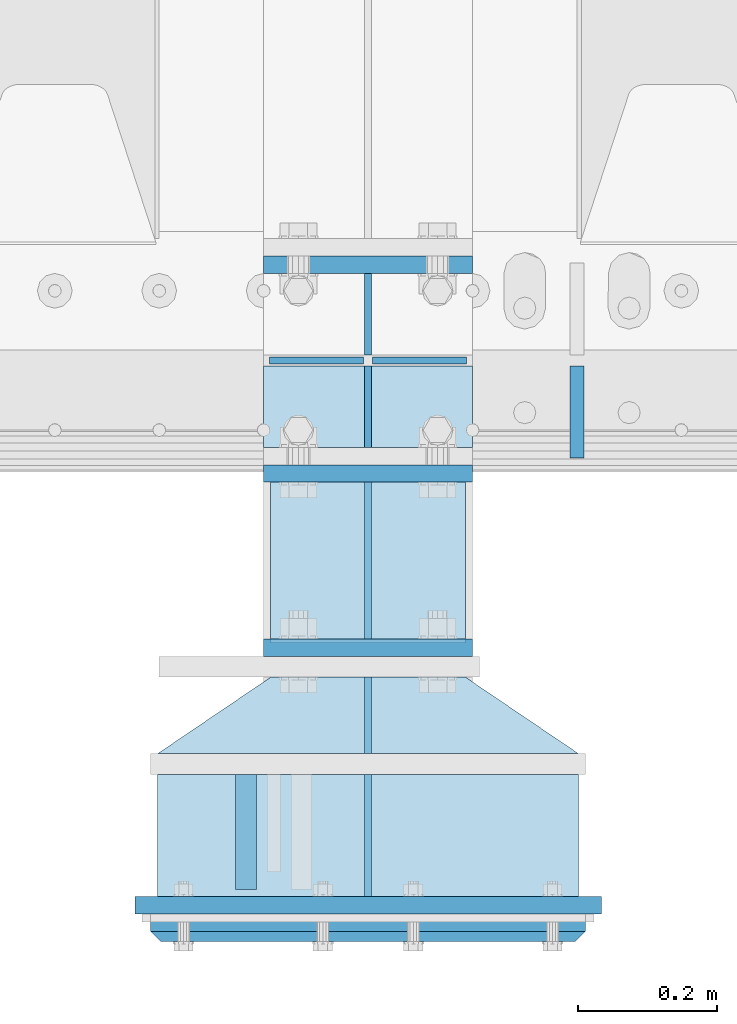
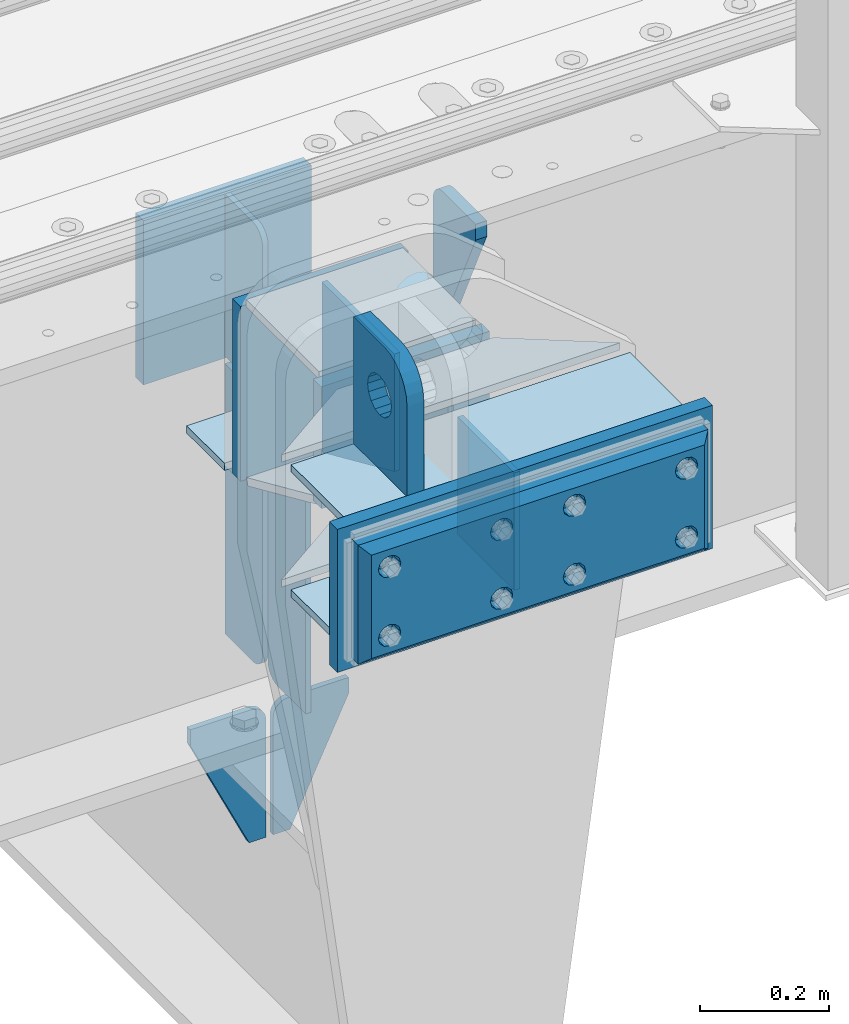
# One storey, part 178 of 208: 22 plates.
"""IFC2X3 building model written with IfcOpenShell, lengths in millimetres."""

import ifcopenshell
import ifcopenshell.guid

model = None  # the IFC model being written
_history = None  # IfcOwnerHistory: only IFC2X3 demands one
_inside = {}  # id of a spatial element -> (the spatial element, [elements in it])
_under = {}  # id of a project, library or spatial element -> (it, [spatial elements below it])
_declared = {}  # id of a project -> (the project, [libraries it declares])
_typed = {}  # id of a type object -> (the type object, [elements of that type])
_made_of = {}  # id of a material, layer set ... -> (it, [elements and type objects made of it])


def new_model(schema):
    """Start an empty IFC model of exactly this schema.

    Asked for "IFC4X3", IfcOpenShell would pick the latest addendum, in which some entities
    have other attributes; the version numbers below select the first issue.
    IFC2X3 requires an IfcOwnerHistory on every rooted entity: one is made here for all.
    """
    global model, _history
    if schema == "IFC4X3":
        model = ifcopenshell.file(schema_version=(4, 3, 0, 0))
    else:
        model = ifcopenshell.file(schema=schema)
    _inside.clear()
    _under.clear()
    _declared.clear()
    _typed.clear()
    _made_of.clear()
    _history = None
    if model.schema == "IFC2X3":
        org = make("IfcOrganization", Name="unknown")
        user = make(
            "IfcPersonAndOrganization",
            ThePerson=make("IfcPerson", FamilyName="unknown"),
            TheOrganization=org,
        )
        app = make(
            "IfcApplication",
            ApplicationDeveloper=org,
            Version="unknown",
            ApplicationFullName="unknown",
            ApplicationIdentifier="unknown",
        )
        _history = make(
            "IfcOwnerHistory",
            OwningUser=user,
            OwningApplication=app,
            ChangeAction="ADDED",
            CreationDate=0,
        )
    return model


def make(cls, **values):
    """One entity of the class cls with the attributes given. An attribute that is None is left unset."""
    return model.create_entity(
        cls, **{name: value for name, value in values.items() if value is not None}
    )


def rooted(cls, **values):
    """An entity with a GlobalId (a new one), such as an element, a storey or a relation."""
    return make(cls, GlobalId=ifcopenshell.guid.new(), OwnerHistory=_history, **values)


def si_unit(unit_type, name, prefix=None):
    """IfcSIUnit, for example si_unit("LENGTHUNIT", "METRE", prefix="MILLI")."""
    return make("IfcSIUnit", UnitType=unit_type, Prefix=prefix, Name=name)


def assignment(units):
    """IfcUnitAssignment: the units of a project."""
    return None if units is None else make("IfcUnitAssignment", Units=units)


def point(xyz):
    """IfcCartesianPoint."""
    return None if xyz is None else make("IfcCartesianPoint", Coordinates=xyz)


def direction(xyz):
    """IfcDirection."""
    return None if xyz is None else make("IfcDirection", DirectionRatios=xyz)


def frame(location, z_axis=None, x_axis=None):
    """IfcAxis2Placement3D, a coordinate frame: its origin and axes. An axis left out is left unset."""
    return make(
        "IfcAxis2Placement3D",
        Location=point(location),
        Axis=direction(z_axis),
        RefDirection=direction(x_axis),
    )


def origin_with_axes():
    """The frame at (0, 0, 0) with the z axis (0, 0, 1) and the x axis (1, 0, 0) written out."""
    return frame((0.0, 0.0, 0.0), z_axis=(0.0, 0.0, 1.0), x_axis=(1.0, 0.0, 0.0))


def place(relative_to, where):
    """IfcLocalPlacement: puts the frame where relative to a parent placement (None: the world)."""
    return make(
        "IfcLocalPlacement", PlacementRelTo=relative_to, RelativePlacement=where
    )


def context(
    kind, dimensions, precision=None, world=None, true_north=None, identifier=None
):
    """IfcGeometricRepresentationContext, for example the 3D "Model" context."""
    return make(
        "IfcGeometricRepresentationContext",
        ContextIdentifier=identifier,
        ContextType=kind,
        CoordinateSpaceDimension=dimensions,
        Precision=precision,
        WorldCoordinateSystem=world,
        TrueNorth=true_north,
    )


def subcontext(parent, identifier, kind, view, scale=None):
    """IfcGeometricRepresentationSubContext, for example "Body" below "Model"."""
    return make(
        "IfcGeometricRepresentationSubContext",
        ContextIdentifier=identifier,
        ContextType=kind,
        ParentContext=parent,
        TargetScale=scale,
        TargetView=view,
    )


def project(units=None, contexts=None):
    """IfcProject with its units and contexts."""
    return rooted(
        "IfcProject",
        Name="project",
        RepresentationContexts=contexts,
        UnitsInContext=assignment(units),
    )


def spatial(cls, under=None, at=None, **own):
    """A site, building, storey or space (cls), placed at a placement, below another one or the project."""
    s = rooted(cls, ObjectPlacement=at, **own)
    if under is not None:
        _under.setdefault(under.id(), (under, []))[1].append(s)
    return s


def faces_of(points, faces, orient=None, outer=None):
    """IfcFace entities. A face is a list of loops; a loop is a list of indices into points, from 0.

    orient and outer hold one flag for each loop. By default every Orientation is true, the
    first loop of a face is its IfcFaceOuterBound and the others are IfcFaceBound.
    """
    made = []
    for i, loops in enumerate(faces):
        bounds = []
        for j, loop in enumerate(loops):
            is_outer = j == 0 if outer is None else outer[i][j]
            bounds.append(
                make(
                    "IfcFaceOuterBound" if is_outer else "IfcFaceBound",
                    Bound=make("IfcPolyLoop", Polygon=[points[k] for k in loop]),
                    Orientation=True if orient is None else orient[i][j],
                )
            )
        made.append(make("IfcFace", Bounds=bounds))
    return made


def faceted_brep(points, faces, orient=None, outer=None, voids=None):
    """IfcFacetedBrep: a solid bounded by flat faces; with voids (closed shells), ...WithVoids."""
    shared = [point(p) for p in points]
    hull = make("IfcClosedShell", CfsFaces=faces_of(shared, faces, orient, outer))
    if voids is None:
        return make("IfcFacetedBrep", Outer=hull)
    return make(
        "IfcFacetedBrepWithVoids",
        Outer=hull,
        Voids=[
            make(cls, CfsFaces=faces_of(shared, fs, o, b)) for cls, fs, o, b in voids
        ],
    )


def shape(context_of_items, identifier, shape_type, items):
    """IfcShapeRepresentation: the items that make up one representation, for example the "Body"."""
    return make(
        "IfcShapeRepresentation",
        ContextOfItems=context_of_items,
        RepresentationIdentifier=identifier,
        RepresentationType=shape_type,
        Items=items,
    )


def material(Name=None, Category=None):
    """IfcMaterial."""
    return make("IfcMaterial", Name=Name, Category=Category)


def made_of(thing, what):
    """Note that an element or type object is made of a material, layer set ...; save() writes the relation."""
    if what is not None:
        _made_of.setdefault(what.id(), (what, []))[1].append(thing)
    return thing


def type_object(cls, material=None, **own):
    """A type object (cls), such as IfcWallType, which elements share."""
    return made_of(rooted(cls, **own), material)


def element(
    cls,
    number,
    at=None,
    inside=None,
    cuts=None,
    type_object=None,
    material=None,
    context=None,
    identifier="Body",
    shape_type=None,
    held_by="IfcProductDefinitionShape",
    body=None,
    shapes=None,
    **own,
):
    """One element of the class cls, such as IfcWall. Its Tag is "e" and its number.

    at: its placement. inside: the storey or other place that contains it. cuts: it is an
    opening in that element (IfcRelVoidsElement). A single representation is given by context,
    identifier, shape_type and body (its items); several are given by shapes. held_by: the class
    of the entity that holds the representations. save() writes the other relations.
    """
    e = rooted(cls, Tag="e%d" % number, ObjectPlacement=at, **own)
    if body is not None:
        shapes = [shape(context, identifier, shape_type, body)]
    if shapes is not None:
        e.Representation = make(held_by, Representations=shapes)
    if inside is not None:
        _inside.setdefault(inside.id(), (inside, []))[1].append(e)
    if cuts is not None:
        rooted(
            "IfcRelVoidsElement", RelatingBuildingElement=cuts, RelatedOpeningElement=e
        )
    if type_object is not None:
        _typed.setdefault(type_object.id(), (type_object, []))[1].append(e)
    return made_of(e, material)


def aggregate(whole, parts):
    """IfcRelAggregates: a whole, such as a stair, and the parts it consists of."""
    return rooted("IfcRelAggregates", RelatingObject=whole, RelatedObjects=parts)


def save(model, path):
    """Write the relations noted so far, then the file.

    IfcRelAggregates (storeys below a building ...), IfcRelContainedInSpatialStructure (elements
    in a storey), IfcRelDefinesByType, IfcRelAssociatesMaterial and IfcRelDeclares: one each for
    every whole, place, type object, material and project.
    """
    for whole, parts in _under.values():
        aggregate(whole, parts)
    for where, things in _inside.values():
        rooted(
            "IfcRelContainedInSpatialStructure",
            RelatedElements=things,
            RelatingStructure=where,
        )
    for kind, things in _typed.values():
        rooted("IfcRelDefinesByType", RelatedObjects=things, RelatingType=kind)
    for what, things in _made_of.values():
        rooted("IfcRelAssociatesMaterial", RelatedObjects=things, RelatingMaterial=what)
    for by, libraries in _declared.values():
        rooted("IfcRelDeclares", RelatingContext=by, RelatedDefinitions=libraries)
    model.write(path)


model = new_model("IFC2X3")

# Units and contexts
model_context = context("Model", 3, precision=1e-05, world=origin_with_axes())
body_context = subcontext(model_context, "Body", "Model", "MODEL_VIEW")
ifc_project = project(units=[si_unit("LENGTHUNIT", "METRE", prefix="MILLI"), si_unit("AREAUNIT", "SQUARE_METRE"), si_unit("VOLUMEUNIT", "CUBIC_METRE"), si_unit("MASSUNIT", "GRAM", prefix="KILO"), si_unit("TIMEUNIT", "SECOND"), si_unit("PLANEANGLEUNIT", "RADIAN"), si_unit("SOLIDANGLEUNIT", "STERADIAN"), si_unit("THERMODYNAMICTEMPERATUREUNIT", "DEGREE_CELSIUS"), si_unit("LUMINOUSINTENSITYUNIT", "LUMEN")], contexts=[model_context])

# Site, building, storey
site_placement = place(None, origin_with_axes())
site = spatial("IfcSite", under=ifc_project, at=site_placement, CompositionType="ELEMENT")
building_placement = place(site_placement, origin_with_axes())
building = spatial("IfcBuilding", under=site, at=building_placement, Name="Standard", CompositionType="ELEMENT")
storey_placement = place(building_placement, origin_with_axes())
storey = spatial("IfcBuildingStorey", under=building, at=storey_placement, Name="Undefined", CompositionType="ELEMENT", Elevation=0.0)

# Plates
ifc_material_1 = material(Name="STEEL/S355N")
plate_type_1 = type_object("IfcPlateType", PredefinedType="NOTDEFINED")
plate_1_placement = place(storey_placement, frame((-30339.9999999412, -175.000000034891, -7.00001822256081), z_axis=(0.0, -1.0, 0.0), x_axis=(1.0, 0.0, 0.0)))
element("IfcPlate", 1, at=plate_1_placement, inside=storey, type_object=plate_type_1, material=ifc_material_1, context=body_context, shape_type="Brep", body=[
    faceted_brep([(0.0, -7.0, 0.0), (0.0, -7.0, 225.0), (0.0, 7.0, 225.0), (0.0, 7.0, 0.0), (280.0, -7.0, 225.0), (280.0, 7.0, 225.0), (280.0, -7.0, 0.0), (280.0, 7.0, 0.0)], [[[0, 1, 2, 3]], [[1, 4, 5, 2]], [[4, 6, 7, 5]], [[6, 0, 3, 7]], [[5, 7, 3, 2]], [[6, 4, 1, 0]]]),
])
plate_type_2 = type_object("IfcPlateType", PredefinedType="NOTDEFINED")
plate_2_placement = place(storey_placement, frame((-30199.9999999406, -770.000000034948, -14.0000182225608), z_axis=(0.0, 0.0, -1.0), x_axis=(0.0, 1.0, 0.0)))
element("IfcPlate", 2, at=plate_2_placement, inside=storey, type_object=plate_type_2, material=ifc_material_1, context=body_context, shape_type="Brep", body=[
    faceted_brep([(0.0, -5.0, 0.0), (0.0, -5.0, 222.0), (0.0, 5.0, 222.0), (0.0, 5.0, 0.0), (175.0, -5.0, 222.0), (175.0, 5.0, 222.0), (175.0, -5.0, 0.0), (175.0, 5.0, 0.0)], [[[0, 1, 2, 3]], [[1, 4, 5, 2]], [[4, 6, 7, 5]], [[6, 0, 3, 7]], [[5, 7, 3, 2]], [[6, 4, 1, 0]]]),
])
plate_type_3 = type_object("IfcPlateType", PredefinedType="NOTDEFINED")
plate_3_placement = place(storey_placement, frame((-30375.5000001148, -594.999999963945, -1.82219628186431e-05), z_axis=(0.0, -1.0, 0.0), x_axis=(0.0, 0.0, 1.0)))
element("IfcPlate", 3, at=plate_3_placement, inside=storey, type_object=plate_type_3, material=ifc_material_1, context=body_context, shape_type="Brep", body=[
    faceted_brep([(125.840713002497, -14.9999995435392, 45.8164574470834), (125.840713002497, 15.0000004564608, 45.8164571470834), (113.837049096103, 15.0000005366674, 53.8370489460988), (113.837049096103, -14.9999994633326, 53.8370492460988), (105.816457297088, 15.0000006567025, 65.8407128524926), (105.816457297088, -14.9999993432975, 65.8407131524926), (103.000000000005, 15.0000007982962, 79.999999850001), (103.000000000005, -14.9999992017038, 80.000000150001), (105.816457297088, 15.00000093989, 94.1592868475093), (105.816457297088, -14.99999906011, 94.1592871475093), (113.837049096103, 15.0000010599251, 106.162950753903), (113.837049096103, -14.9999989400749, 106.162951053903), (125.840713002497, 15.0000011401316, 114.183542552919), (125.840713002497, -14.9999988598684, 114.183542852919), (140.000000000005, 15.0000011682969, 116.999999850001), (140.000000000005, -14.9999988317031, 117.000000150001), (154.159286997514, 15.0000011401316, 114.183542552919), (154.159286997514, -14.9999988598684, 114.183542852919), (166.162950903908, 15.0000010599251, 106.162950753903), (166.162950903908, -14.9999989400749, 106.162951053903), (174.183542702923, 15.00000093989, 94.1592868475093), (174.183542702923, -14.99999906011, 94.1592871475093), (177.000000000005, 15.0000007982962, 79.999999850001), (177.000000000005, -14.9999992017038, 80.000000150001), (174.183542702923, 15.0000006567025, 65.8407128524927), (174.183542702923, -14.9999993432975, 65.8407131524928), (166.162950903908, 15.0000005366674, 53.8370489460988), (166.162950903908, -14.9999994633326, 53.8370492460988), (154.159286997514, 15.0000004564608, 45.8164571470834), (154.159286997514, -14.9999995435392, 45.8164574470834), (140.000000000005, 15.0000004282956, 42.999999850001), (140.000000000005, -14.9999995717044, 43.000000150001), (240.000015258789, -14.9999999999964, -2.06341610464733e-10), (240.0, -15.0, 95.0), (237.614807840235, -15.0, 113.117333157177), (230.621778264911, -15.0, 130.0), (219.497474683058, -15.0, 144.497474683058), (205.0, -15.0, 155.621778264911), (188.117333157176, -15.0, 162.614807840235), (170.0, -15.0, 165.0), (-1.40620068123098e-06, -15.0, 165.0), (0.0, -15.0, 0.0), (0.0, 15.0, 0.0), (240.000015258789, 15.0000000000036, -2.06341610464733e-10), (240.0, 15.0, 95.0), (237.614807840235, 15.0, 113.117333157177), (230.621778264911, 15.0, 130.0), (219.497474683058, 15.0, 144.497474683058), (205.0, 15.0, 155.621778264911), (188.117333157176, 15.0, 162.614807840235), (170.0, 15.0, 165.0), (-1.40620068123098e-06, 15.0, 165.0)], [[[0, 1, 2, 3]], [[3, 2, 4, 5]], [[5, 4, 6, 7]], [[7, 6, 8, 9]], [[9, 8, 10, 11]], [[11, 10, 12, 13]], [[13, 12, 14, 15]], [[15, 14, 16, 17]], [[17, 16, 18, 19]], [[19, 18, 20, 21]], [[21, 20, 22, 23]], [[23, 22, 24, 25]], [[25, 24, 26, 27]], [[27, 26, 28, 29]], [[29, 28, 30, 31]], [[31, 30, 1, 0]], [[32, 33, 34, 35, 36, 37, 38, 39, 40, 41], [3, 5, 7, 9, 11, 13, 15, 17, 19, 21, 23, 25, 27, 29, 31, 0]], [[32, 41, 42, 43]], [[33, 32, 43, 44]], [[34, 33, 44, 45]], [[35, 34, 45, 46]], [[36, 35, 46, 47]], [[37, 36, 47, 48]], [[38, 37, 48, 49]], [[39, 38, 49, 50]], [[40, 39, 50, 51]], [[41, 40, 51, 42]], [[50, 49, 48, 47, 46, 45, 44, 43, 42, 51], [26, 24, 22, 20, 18, 16, 14, 12, 10, 8, 6, 4, 2, 1, 30, 28]]]),
])
plate_type_4 = type_object("IfcPlateType", PredefinedType="NOTDEFINED")
plate_4_placement = place(storey_placement, frame((-30349.9999999412, -162.500000034888, -340.000018222561), z_axis=(0.0, 0.0, 1.0), x_axis=(1.0, 0.0, 0.0)))
element("IfcPlate", 4, at=plate_4_placement, inside=storey, type_object=plate_type_4, material=ifc_material_1, context=body_context, shape_type="Brep", body=[
    faceted_brep([(0.0, -12.5, 0.0), (0.0, -12.5, 330.0), (0.0, 12.5, 330.0), (0.0, 12.5, 0.0), (300.0, -12.5, 330.0), (300.0, 12.5, 330.0), (300.0, -12.5, 0.0), (300.0, 12.5, 0.0)], [[[0, 1, 2, 3]], [[1, 4, 5, 2]], [[4, 6, 7, 5]], [[6, 0, 3, 7]], [[5, 7, 3, 2]], [[6, 4, 1, 0]]]),
])
plate_5_placement = place(storey_placement, frame((-30350.0, 137.5, -340.0), z_axis=(0.0, 0.0, 1.0), x_axis=(1.0, 0.0, 0.0)))
element("IfcPlate", 5, at=plate_5_placement, inside=storey, type_object=plate_type_4, material=ifc_material_1, context=body_context, shape_type="Brep", body=[
    faceted_brep([(0.0, -12.5, 0.0), (0.0, -12.5, 310.0), (0.0, 12.5, 310.0), (0.0, 12.5, 0.0), (300.0, -12.5, 310.0), (300.0, 12.5, 310.0), (300.0, -12.5, 0.0), (300.0, 12.5, 0.0)], [[[0, 1, 2, 3]], [[1, 4, 5, 2]], [[4, 6, 7, 5]], [[6, 0, 3, 7]], [[5, 7, 3, 2]], [[6, 4, 1, 0]]]),
])
plate_type_5 = type_object("IfcPlateType", PredefinedType="NOTDEFINED")
plate_6_placement = place(storey_placement, frame((-30350.0, -8.0, -343.0), z_axis=(0.0, -1.0, 0.0), x_axis=(1.0, 0.0, 0.0)))
element("IfcPlate", 6, at=plate_6_placement, inside=storey, type_object=plate_type_5, material=ifc_material_1, context=body_context, shape_type="Brep", body=[
    faceted_brep([(0.0, -7.0, 0.0), (0.0, -7.0, 117.0), (0.0, 7.0, 117.0), (0.0, 7.0, 0.0), (300.0, -7.0, 117.0), (300.0, 7.0, 117.0), (300.0, -7.0, 0.0), (300.0, 7.0, 0.0)], [[[0, 1, 2, 3]], [[1, 4, 5, 2]], [[4, 6, 7, 5]], [[6, 0, 3, 7]], [[5, 7, 3, 2]], [[6, 4, 1, 0]]]),
])
plate_type_6 = type_object("IfcPlateType", PredefinedType="NOTDEFINED")
for number, where, z_axis, x_axis in (
    (7, (-30200.0, -8.0, -350.0), (0.0, 0.0, -1.0), (0.0, -1.0, 0.0)),
    (8, (-30200.0, 8.0, -350.0), (0.0, 0.0, -1.0), (0.0, 1.0, 0.0)),
):
    element("IfcPlate", number, at=place(storey_placement, frame(where, z_axis=z_axis, x_axis=x_axis)), inside=storey, type_object=plate_type_6, material=ifc_material_1, context=body_context, shape_type="Brep", body=[
        faceted_brep([(0.0, -5.0, 0.0), (0.0, -5.0, 480.0), (0.0, 5.0, 480.0), (0.0, 5.0, 0.0), (0.455767409634063, -5.0, 485.209445330008), (0.455767409634063, 5.0, 485.209445330008), (1.80922137642301, -5.0, 490.26060429977), (1.80922137642301, 5.0, 490.26060429977), (4.01923788646673, -5.0, 495.0), (4.01923788646673, 5.0, 495.0), (7.01866670643085, -5.0, 499.283628290596), (7.01866670643085, 5.0, 499.283628290596), (10.7163717094036, -5.0, 502.981333293569), (10.7163717094036, 5.0, 502.981333293569), (15.0, -5.0, 505.980762113533), (15.0, 5.0, 505.980762113533), (19.7393957002296, -5.0, 508.190778623577), (19.7393957002296, 5.0, 508.190778623577), (24.7905546699922, -5.0, 509.544232590366), (24.7905546699922, 5.0, 509.544232590366), (30.0, -5.0, 510.0), (30.0, 5.0, 510.0), (117.0, -5.0, 510.0), (117.0, 5.0, 510.0), (117.0, -5.0, 0.0), (117.0, 5.0, 0.0)], [[[0, 1, 2, 3]], [[1, 4, 5, 2]], [[4, 6, 7, 5]], [[6, 8, 9, 7]], [[8, 10, 11, 9]], [[10, 12, 13, 11]], [[12, 14, 15, 13]], [[14, 16, 17, 15]], [[16, 18, 19, 17]], [[18, 20, 21, 19]], [[20, 22, 23, 21]], [[22, 24, 25, 23]], [[24, 0, 3, 25]], [[5, 7, 9, 11, 13, 15, 17, 19, 21, 23, 25, 3, 2]], [[24, 22, 20, 18, 16, 14, 12, 10, 8, 6, 4, 1, 0]]]),
    ])
plate_7_placement = place(storey_placement, frame((-30200.0, 8.0, -30.0), z_axis=(0.0, 0.0, -1.0), x_axis=(0.0, 1.0, 0.0)))
element("IfcPlate", 9, at=plate_7_placement, inside=storey, type_object=plate_type_6, material=ifc_material_1, context=body_context, shape_type="Brep", body=[
    faceted_brep([(0.0, -5.0, 30.0), (0.0, -5.0, 306.0), (0.0, 5.0, 306.0), (0.0, 5.0, 30.0), (117.0, -5.0, 306.0), (117.0, 5.0, 306.0), (117.0, -5.0, 0.0), (117.0, 5.0, 0.0), (30.0, -5.0, 0.0), (30.0, 5.0, 0.0), (24.7905546699922, -5.0, 0.455767409633758), (24.7905546699922, 5.0, 0.455767409633758), (19.7393957002296, -5.0, 1.80922137642275), (19.7393957002296, 5.0, 1.80922137642275), (15.0, -5.0, 4.01923788646684), (15.0, 5.0, 4.01923788646684), (10.7163717094036, -5.0, 7.01866670643066), (10.7163717094036, 5.0, 7.01866670643066), (7.01866670643085, -5.0, 10.7163717094038), (7.01866670643085, 5.0, 10.7163717094038), (4.01923788646673, -5.0, 15.0), (4.01923788646673, 5.0, 15.0), (1.80922137642301, -5.0, 19.7393957002299), (1.80922137642301, 5.0, 19.7393957002299), (0.455767409634063, -5.0, 24.7905546699921), (0.455767409634063, 5.0, 24.7905546699921)], [[[0, 1, 2, 3]], [[1, 4, 5, 2]], [[4, 6, 7, 5]], [[6, 8, 9, 7]], [[8, 10, 11, 9]], [[10, 12, 13, 11]], [[12, 14, 15, 13]], [[14, 16, 17, 15]], [[16, 18, 19, 17]], [[18, 20, 21, 19]], [[20, 22, 23, 21]], [[22, 24, 25, 23]], [[24, 0, 3, 25]], [[5, 7, 9, 11, 13, 15, 17, 19, 21, 23, 25, 3, 2]], [[24, 22, 20, 18, 16, 14, 12, 10, 8, 6, 4, 1, 0]]]),
])
plate_type_7 = type_object("IfcPlateType", PredefinedType="NOTDEFINED")
for number, where, z_axis, x_axis in (
    (10, (-30206.4999999409, -3.49269839716726e-08, -915.000018222559), (0.0, 0.0, -1.0), (-1.0, 0.0, 0.0)),
    (11, (-30193.4999999409, -3.49320998793701e-08, -915.000018222559), (0.0, 0.0, -1.0), (1.0, 0.0, 0.0)),
):
    element("IfcPlate", number, at=place(storey_placement, frame(where, z_axis=z_axis, x_axis=x_axis)), inside=storey, type_object=plate_type_7, material=ifc_material_1, context=body_context, shape_type="Brep", body=[
        faceted_brep([(0.0, -5.0, 27.0), (0.0, -5.0, 250.0), (0.0, 5.0, 250.0), (0.0, 5.0, 27.0), (30.0, -5.0, 250.0), (30.0, 5.0, 250.0), (135.0, -5.0, 30.0), (135.0, 5.0, 30.0), (135.0, -5.0, 0.0), (135.0, 5.0, 0.0), (27.0, -5.0, 0.0), (27.0, 5.0, 0.0), (22.3114992029914, -5.0, 0.410190668670339), (22.3114992029914, 5.0, 0.410190668670339), (17.7654561302079, -5.0, 1.62829923878041), (17.7654561302079, 5.0, 1.62829923878041), (13.5, -5.0, 3.61731409782021), (13.5, 5.0, 3.61731409782021), (9.64473453846222, -5.0, 6.31680003578765), (9.64473453846222, 5.0, 6.31680003578765), (6.31680003578731, -5.0, 9.64473453846347), (6.31680003578731, 5.0, 9.64473453846347), (3.61731409782078, -5.0, 13.5), (3.61731409782078, 5.0, 13.5), (1.62829923877871, -5.0, 17.765456130207), (1.62829923877871, 5.0, 17.765456130207), (0.410190668670111, -5.0, 22.3114992029929), (0.410190668670111, 5.0, 22.3114992029929)], [[[0, 1, 2, 3]], [[1, 4, 5, 2]], [[4, 6, 7, 5]], [[6, 8, 9, 7]], [[8, 10, 11, 9]], [[10, 12, 13, 11]], [[12, 14, 15, 13]], [[14, 16, 17, 15]], [[16, 18, 19, 17]], [[18, 20, 21, 19]], [[20, 22, 23, 21]], [[22, 24, 25, 23]], [[24, 26, 27, 25]], [[26, 0, 3, 27]], [[5, 7, 9, 11, 13, 15, 17, 19, 21, 23, 25, 27, 3, 2]], [[26, 24, 22, 20, 18, 16, 14, 12, 10, 8, 6, 4, 1, 0]]]),
    ])
plate_type_8 = type_object("IfcPlateType", PredefinedType="NOTDEFINED")
plate_8_placement = place(storey_placement, frame((-29900.0, -140.0, -30.0), z_axis=(0.0, 0.0, -1.0), x_axis=(0.0, 1.0, 0.0)))
element("IfcPlate", 12, at=plate_8_placement, inside=storey, type_object=plate_type_8, material=ifc_material_1, context=body_context, shape_type="Brep", body=[
    faceted_brep([(0.0, -10.0, 0.0), (0.0, -10.0, 30.0), (0.0, 10.0, 30.0), (0.0, 10.0, 0.0), (102.0, -10.0, 250.0), (102.0, 10.0, 250.0), (132.0, -10.0, 250.0), (132.0, 10.0, 250.0), (132.0, -10.0, 30.0), (132.0, 10.0, 30.0), (131.544232590366, -10.0, 24.790554669992), (131.544232590366, 10.0, 24.790554669992), (130.190778623577, -10.0, 19.7393957002299), (130.190778623577, 10.0, 19.7393957002299), (127.980762113533, -10.0, 15.0), (127.980762113533, 10.0, 15.0), (124.981333293569, -10.0, 10.7163717094038), (124.981333293569, 10.0, 10.7163717094038), (121.283628290596, -10.0, 7.01866670643062), (121.283628290596, 10.0, 7.01866670643062), (117.0, -10.0, 4.01923788646684), (117.0, 10.0, 4.01923788646684), (112.26060429977, -10.0, 1.80922137642278), (112.26060429977, 10.0, 1.80922137642278), (107.209445330008, -10.0, 0.455767409633722), (107.209445330008, 10.0, 0.455767409633722), (102.0, -10.0, 0.0), (102.0, 10.0, 0.0)], [[[0, 1, 2, 3]], [[1, 4, 5, 2]], [[4, 6, 7, 5]], [[6, 8, 9, 7]], [[8, 10, 11, 9]], [[10, 12, 13, 11]], [[12, 14, 15, 13]], [[14, 16, 17, 15]], [[16, 18, 19, 17]], [[18, 20, 21, 19]], [[20, 22, 23, 21]], [[22, 24, 25, 23]], [[24, 26, 27, 25]], [[26, 0, 3, 27]], [[5, 7, 9, 11, 13, 15, 17, 19, 21, 23, 25, 27, 3, 2]], [[26, 24, 22, 20, 18, 16, 14, 12, 10, 8, 6, 4, 1, 0]]]),
])
plate_type_9 = type_object("IfcPlateType", PredefinedType="NOTDEFINED")
plate_9_placement = place(storey_placement, frame((-30339.9999999412, -177.842969295966, -342.39669906348), z_axis=(0.0, -0.913811548702731, 0.406138465867881), x_axis=(1.0, 0.0, 0.0)))
element("IfcPlate", 13, at=plate_9_placement, inside=storey, type_object=plate_type_9, material=ifc_material_1, context=body_context, shape_type="Brep", body=[
    faceted_brep([(0.0, -7.0, 0.0), (0.0, -7.0, 246.221450805664), (0.0, 7.0, 246.221450805664), (0.0, 7.0, 0.0), (280.0, -7.0, 246.221450805664), (280.0, 7.0, 246.221450805664), (280.0, -7.0, 0.0), (280.0, 7.0, 0.0)], [[[0, 1, 2, 3]], [[1, 4, 5, 2]], [[4, 6, 7, 5]], [[6, 0, 3, 7]], [[5, 7, 3, 2]], [[6, 4, 1, 0]]]),
])
ifc_material_2 = material()
plate_type_10 = type_object("IfcPlateType", PredefinedType="NOTDEFINED")
for number, where, z_axis, x_axis in (
    (14, (-29897.4999999399, -595.000000035039, -7.00001822256081), (0.0, -1.0, 0.0), (-1.0, 0.0, 0.0)),
    (15, (-29897.4999999399, -595.000000035039, -243.000018222561), (0.0, -1.0, 0.0), (-1.0, 0.0, 0.0)),
):
    element("IfcPlate", number, at=place(storey_placement, frame(where, z_axis=z_axis, x_axis=x_axis)), inside=storey, type_object=plate_type_10, material=ifc_material_2, context=body_context, shape_type="Brep", body=[
        faceted_brep([(0.0, -7.0, 0.0), (0.0, -7.0, 175.0), (0.0, 7.0, 175.0), (0.0, 7.0, 0.0), (605.0, -7.0, 175.0), (605.0, 7.0, 175.0), (605.0, -7.0, 0.0), (605.0, 7.0, 0.0)], [[[0, 1, 2, 3]], [[1, 4, 5, 2]], [[4, 6, 7, 5]], [[6, 0, 3, 7]], [[5, 7, 3, 2]], [[6, 4, 1, 0]]]),
    ])
plate_type_11 = type_object("IfcPlateType", PredefinedType="NOTDEFINED")
plate_10_placement = place(storey_placement, frame((-30199.9999999407, -565.000000034942, -14.0000182225608), z_axis=(0.0, 0.0, -1.0), x_axis=(0.0, 1.0, 0.0)))
element("IfcPlate", 16, at=plate_10_placement, inside=storey, type_object=plate_type_11, material=ifc_material_1, context=body_context, shape_type="Brep", body=[
    faceted_brep([(0.0, -5.0, 0.0), (0.0, -5.0, 222.0), (0.0, 5.0, 222.0), (0.0, 5.0, 0.0), (110.0, -5.0, 222.0), (110.0, 5.0, 222.0), (110.0, -5.0, 0.0), (110.0, 5.0, 0.0)], [[[0, 1, 2, 3]], [[1, 4, 5, 2]], [[4, 6, 7, 5]], [[6, 0, 3, 7]], [[5, 7, 3, 2]], [[6, 4, 1, 0]]]),
])
plate_type_12 = type_object("IfcPlateType", PredefinedType="NOTDEFINED")
for number, where, z_axis, x_axis in (
    (17, (-29897.4999999399, -565.000000035038, -243.000018222561), (-0.560566412034006, -0.828109472050236, 0.0), (-0.828109472050236, 0.560566412034006, 0.0)),
    (18, (-29897.4999999399, -565.000000035038, -7.00001822256081), (-0.560566412034006, -0.828109472050236, 0.0), (-0.828109472050236, 0.560566412034006, 0.0)),
):
    element("IfcPlate", number, at=place(storey_placement, frame(where, z_axis=z_axis, x_axis=x_axis)), inside=storey, type_object=plate_type_12, material=ifc_material_1, context=body_context, shape_type="Brep", body=[
        faceted_brep([(0.0, -7.0, 0.0), (501.006225585941, -7.0, 339.142669677734), (501.006225585941, 7.0, 339.142669677734), (0.0, 7.0, 0.0), (428.100738525394, -7.0, 156.958602905273), (428.100738525394, 7.0, 156.958602905273), (196.230087280273, -7.0, 3.05590219795704e-10), (196.230087280273, 7.0, 3.05590219795704e-10)], [[[0, 1, 2, 3]], [[1, 4, 5, 2]], [[4, 6, 7, 5]], [[6, 0, 3, 7]], [[5, 7, 3, 2]], [[6, 4, 1, 0]]]),
    ])
plate_type_13 = type_object("IfcPlateType", PredefinedType="NOTDEFINED")
plate_11_placement = place(storey_placement, frame((-30349.9999999411, -412.500000034893, -240.000018222561), z_axis=(0.0, 0.0, 1.0), x_axis=(1.0, 0.0, 0.0)))
element("IfcPlate", 19, at=plate_11_placement, inside=storey, type_object=plate_type_13, material=ifc_material_1, context=body_context, shape_type="Brep", body=[
    faceted_brep([(0.0, -12.5, 0.0), (0.0, -12.5, 230.0), (0.0, 12.5, 230.0), (0.0, 12.5, 0.0), (300.0, -12.5, 230.0), (300.0, 12.5, 230.0), (300.0, -12.5, 0.0), (300.0, 12.5, 0.0)], [[[0, 1, 2, 3]], [[1, 4, 5, 2]], [[4, 6, 7, 5]], [[6, 0, 3, 7]], [[5, 7, 3, 2]], [[6, 4, 1, 0]]]),
])
ifc_material_3 = material()
plate_type_14 = type_object("IfcPlateType", PredefinedType="NOTDEFINED")
plate_12_placement = place(storey_placement, frame((-29887.4999999398, -815.000000035047, -12.5000182225608), z_axis=(0.0, 0.0, -1.0), x_axis=(-1.0, 0.0, 0.0)))
element("IfcPlate", 20, at=plate_12_placement, inside=storey, type_object=plate_type_14, material=ifc_material_3, context=body_context, shape_type="Brep", body=[
    faceted_brep([(0.0, -5.0, 0.0), (15.0, -20.0, 15.0), (15.0, -20.0, 210.0), (0.0, -5.0, 225.0), (625.0, -5.0, 225.0), (610.0, -20.0, 210.0), (610.0, -20.0, 15.0), (625.0, -5.0, 0.0), (625.0, 15.0, 0.0), (620.0, 20.0, 5.0), (620.0, 20.0, 220.0), (625.0, 15.0, 225.0), (0.0, 15.0, 225.0), (5.0, 20.0, 220.0), (5.0, 20.0, 5.0), (0.0, 15.0, 0.0), (30.179491924413, 5.00000000001501, 37.4999999999982), (37.5000000001019, 5.00000000001501, 30.1794919243094), (47.5000000001019, 5.00000000001501, 27.4999999999982), (57.5000000001019, 5.00000000001501, 30.1794919243094), (64.8205080757907, 5.00000000001501, 37.4999999999982), (67.5000000001019, 5.00000000001501, 47.4999999999982), (64.8205080757907, 5.00000000001501, 57.4999999999982), (57.5000000001019, 5.00000000001501, 64.8205080756869), (47.5000000001019, 5.00000000001501, 67.4999999999982), (37.5000000001019, 5.00000000001501, 64.820508075687), (30.179491924413, 5.00000000001501, 57.4999999999982), (27.5000000001019, 5.00000000001501, 47.4999999999982), (37.5000000001019, -20.0, 30.1794919243094), (30.179491924413, -20.0, 37.4999999999982), (47.5000000001019, -20.0, 27.4999999999982), (57.5000000001019, -20.0, 30.1794919243094), (64.8205080757907, -20.0, 37.4999999999982), (67.5000000001019, -20.0, 47.4999999999982), (64.8205080757907, -20.0, 57.4999999999982), (57.5000000001019, -20.0, 64.8205080756869), (47.5000000001019, -20.0, 67.4999999999982), (37.5000000001019, -20.0, 64.820508075687), (30.179491924413, -20.0, 57.4999999999982), (27.5000000001019, -20.0, 47.4999999999982), (230.179491924951, 5.00000000007765, 37.4999999999982), (237.50000000064, 5.00000000007765, 30.1794919243094), (247.50000000064, 5.00000000007765, 27.4999999999982), (257.50000000064, 5.00000000007765, 30.1794919243094), (264.820508076329, 5.00000000007765, 37.4999999999982), (267.50000000064, 5.00000000007765, 47.4999999999982), (264.820508076329, 5.00000000007765, 57.4999999999982), (257.50000000064, 5.00000000007765, 64.8205080756869), (247.50000000064, 5.00000000007765, 67.4999999999982), (237.50000000064, 5.00000000007765, 64.820508075687), (230.179491924951, 5.00000000007765, 57.4999999999982), (227.50000000064, 5.00000000007765, 47.4999999999982), (230.179491924951, -20.0, 37.4999999999982), (227.50000000064, -20.0, 47.4999999999982), (237.50000000064, -20.0, 30.1794919243094), (247.50000000064, -20.0, 27.4999999999982), (257.50000000064, -20.0, 30.1794919243094), (264.820508076329, -20.0, 37.4999999999982), (267.50000000064, -20.0, 47.4999999999982), (264.820508076329, -20.0, 57.4999999999982), (257.50000000064, -20.0, 64.8205080756869), (247.50000000064, -20.0, 67.4999999999982), (237.50000000064, -20.0, 64.820508075687), (230.179491924951, -20.0, 57.4999999999982), (560.179491925839, 5.0000000001811, 37.4999999999982), (567.500000001528, 5.0000000001811, 30.1794919243094), (577.500000001528, 5.0000000001811, 27.4999999999982), (587.500000001528, 5.0000000001811, 30.1794919243094), (594.820508077217, 5.0000000001811, 37.4999999999982), (597.500000001528, 5.0000000001811, 47.4999999999982), (594.820508077217, 5.0000000001811, 57.4999999999982), (587.500000001528, 5.0000000001811, 64.8205080756869), (577.500000001528, 5.0000000001811, 67.4999999999982), (567.500000001528, 5.0000000001811, 64.820508075687), (560.179491925839, 5.0000000001811, 57.4999999999982), (557.500000001528, 5.0000000001811, 47.4999999999982), (560.179491925839, -20.0, 37.4999999999982), (557.500000001528, -20.0, 47.4999999999982), (567.500000001528, -20.0, 30.1794919243094), (577.500000001528, -20.0, 27.4999999999982), (587.500000001528, -20.0, 30.1794919243094), (594.820508077217, -20.0, 37.4999999999982), (597.500000001528, -20.0, 47.4999999999982), (594.820508077217, -20.0, 57.4999999999982), (587.500000001528, -20.0, 64.8205080756869), (577.500000001528, -20.0, 67.4999999999982), (567.500000001528, -20.0, 64.820508075687), (560.179491925839, -20.0, 57.4999999999982), (560.179491925839, 5.0000000001811, 167.499999999998), (567.500000001528, 5.0000000001811, 160.179491924309), (577.500000001528, 5.0000000001811, 157.499999999998), (587.500000001528, 5.0000000001811, 160.179491924309), (594.820508077217, 5.0000000001811, 167.499999999998), (597.500000001528, 5.0000000001811, 177.499999999998), (594.820508077217, 5.0000000001811, 187.499999999998), (587.500000001528, 5.0000000001811, 194.820508075687), (577.500000001528, 5.0000000001811, 197.499999999998), (567.500000001528, 5.0000000001811, 194.820508075687), (560.179491925839, 5.0000000001811, 187.499999999998), (557.500000001528, 5.0000000001811, 177.499999999998), (560.179491925839, -20.0, 167.499999999998), (557.500000001528, -20.0, 177.499999999998), (567.500000001528, -20.0, 160.179491924309), (577.500000001528, -20.0, 157.499999999998), (587.500000001528, -20.0, 160.179491924309), (594.820508077217, -20.0, 167.499999999998), (597.500000001528, -20.0, 177.499999999998), (594.820508077217, -20.0, 187.499999999998), (587.500000001528, -20.0, 194.820508075687), (577.500000001528, -20.0, 197.499999999998), (567.500000001528, -20.0, 194.820508075687), (560.179491925839, -20.0, 187.499999999998), (230.179491924951, 5.00000000007765, 167.499999999998), (237.50000000064, 5.00000000007765, 160.179491924309), (247.50000000064, 5.00000000007765, 157.499999999998), (257.50000000064, 5.00000000007765, 160.179491924309), (264.820508076329, 5.00000000007765, 167.499999999998), (267.50000000064, 5.00000000007765, 177.499999999998), (264.820508076329, 5.00000000007765, 187.499999999998), (257.50000000064, 5.00000000007765, 194.820508075687), (247.50000000064, 5.00000000007765, 197.499999999998), (237.50000000064, 5.00000000007765, 194.820508075687), (230.179491924951, 5.00000000007765, 187.499999999998), (227.50000000064, 5.00000000007765, 177.499999999998), (230.179491924951, -20.0, 167.499999999998), (227.50000000064, -20.0, 177.499999999998), (237.50000000064, -20.0, 160.179491924309), (247.50000000064, -20.0, 157.499999999998), (257.50000000064, -20.0, 160.179491924309), (264.820508076329, -20.0, 167.499999999998), (267.50000000064, -20.0, 177.499999999998), (264.820508076329, -20.0, 187.499999999998), (257.50000000064, -20.0, 194.820508075687), (247.50000000064, -20.0, 197.499999999998), (237.50000000064, -20.0, 194.820508075687), (230.179491924951, -20.0, 187.499999999998), (30.179491924413, 5.00000000001501, 167.499999999998), (37.5000000001019, 5.00000000001501, 160.179491924309), (47.5000000001019, 5.00000000001501, 157.499999999998), (57.5000000001019, 5.00000000001501, 160.179491924309), (64.8205080757907, 5.00000000001501, 167.499999999998), (67.5000000001019, 5.00000000001501, 177.499999999998), (64.8205080757907, 5.00000000001501, 187.499999999998), (57.5000000001019, 5.00000000001501, 194.820508075687), (47.5000000001019, 5.00000000001501, 197.499999999998), (37.5000000001019, 5.00000000001501, 194.820508075687), (30.179491924413, 5.00000000001501, 187.499999999998), (27.5000000001019, 5.00000000001501, 177.499999999998), (30.179491924413, -20.0, 167.499999999998), (27.5000000001019, -20.0, 177.499999999998), (37.5000000001019, -20.0, 160.179491924309), (47.5000000001019, -20.0, 157.499999999998), (57.5000000001019, -20.0, 160.179491924309), (64.8205080757907, -20.0, 167.499999999998), (67.5000000001019, -20.0, 177.499999999998), (64.8205080757907, -20.0, 187.499999999998), (57.5000000001019, -20.0, 194.820508075687), (47.5000000001019, -20.0, 197.499999999998), (37.5000000001019, -20.0, 194.820508075687), (30.179491924413, -20.0, 187.499999999998), (360.179491925301, 5.00000000011846, 167.499999999998), (367.50000000099, 5.00000000011846, 160.179491924309), (377.50000000099, 5.00000000011846, 157.499999999998), (387.50000000099, 5.00000000011846, 160.179491924309), (394.820508076678, 5.00000000011846, 167.499999999998), (397.50000000099, 5.00000000011846, 177.499999999998), (394.820508076678, 5.00000000011846, 187.499999999998), (387.50000000099, 5.00000000011846, 194.820508075687), (377.50000000099, 5.00000000011846, 197.499999999998), (367.50000000099, 5.00000000011846, 194.820508075687), (360.179491925301, 5.00000000011846, 187.499999999998), (357.50000000099, 5.00000000011846, 177.499999999998), (360.179491925301, -20.0, 167.499999999998), (357.50000000099, -20.0, 177.499999999998), (367.50000000099, -20.0, 160.179491924309), (377.50000000099, -20.0, 157.499999999998), (387.50000000099, -20.0, 160.179491924309), (394.820508076678, -20.0, 167.499999999998), (397.50000000099, -20.0, 177.499999999998), (394.820508076678, -20.0, 187.499999999998), (387.50000000099, -20.0, 194.820508075687), (377.50000000099, -20.0, 197.499999999998), (367.50000000099, -20.0, 194.820508075687), (360.179491925301, -20.0, 187.499999999998), (360.179491925301, 5.00000000011846, 37.4999999999982), (367.50000000099, 5.00000000011846, 30.1794919243094), (377.50000000099, 5.00000000011846, 27.4999999999982), (387.50000000099, 5.00000000011846, 30.1794919243094), (394.820508076678, 5.00000000011846, 37.4999999999982), (397.50000000099, 5.00000000011846, 47.4999999999982), (394.820508076678, 5.00000000011846, 57.4999999999982), (387.50000000099, 5.00000000011846, 64.8205080756869), (377.50000000099, 5.00000000011846, 67.4999999999982), (367.50000000099, 5.00000000011846, 64.820508075687), (360.179491925301, 5.00000000011846, 57.4999999999982), (357.50000000099, 5.00000000011846, 47.4999999999982), (360.179491925301, -20.0, 37.4999999999982), (357.50000000099, -20.0, 47.4999999999982), (367.50000000099, -20.0, 30.1794919243094), (377.50000000099, -20.0, 27.4999999999982), (387.50000000099, -20.0, 30.1794919243094), (394.820508076678, -20.0, 37.4999999999982), (397.50000000099, -20.0, 47.4999999999982), (394.820508076678, -20.0, 57.4999999999982), (387.50000000099, -20.0, 64.8205080756869), (377.50000000099, -20.0, 67.4999999999982), (367.50000000099, -20.0, 64.820508075687), (360.179491925301, -20.0, 57.4999999999982)], [[[0, 1, 2, 3]], [[4, 5, 6, 7]], [[8, 9, 10, 11]], [[12, 13, 14, 15]], [[15, 14, 9, 8]], [[5, 4, 3, 2]], [[13, 12, 11, 10]], [[7, 6, 1, 0]], [[16, 17, 18, 19, 20, 21, 22, 23, 24, 25, 26, 27]], [[28, 17, 16, 29]], [[30, 18, 17, 28]], [[31, 19, 18, 30]], [[32, 20, 19, 31]], [[33, 21, 20, 32]], [[34, 22, 21, 33]], [[35, 23, 22, 34]], [[36, 24, 23, 35]], [[37, 25, 24, 36]], [[38, 26, 25, 37]], [[39, 27, 26, 38]], [[29, 16, 27, 39]], [[11, 12, 3, 4]], [[8, 11, 4, 7]], [[7, 0, 15, 8]], [[14, 13, 10, 9]], [[12, 15, 0, 3]], [[40, 41, 42, 43, 44, 45, 46, 47, 48, 49, 50, 51]], [[52, 40, 51, 53]], [[54, 41, 40, 52]], [[55, 42, 41, 54]], [[56, 43, 42, 55]], [[57, 44, 43, 56]], [[58, 45, 44, 57]], [[59, 46, 45, 58]], [[60, 47, 46, 59]], [[61, 48, 47, 60]], [[62, 49, 48, 61]], [[63, 50, 49, 62]], [[53, 51, 50, 63]], [[64, 65, 66, 67, 68, 69, 70, 71, 72, 73, 74, 75]], [[76, 64, 75, 77]], [[78, 65, 64, 76]], [[79, 66, 65, 78]], [[80, 67, 66, 79]], [[81, 68, 67, 80]], [[82, 69, 68, 81]], [[83, 70, 69, 82]], [[84, 71, 70, 83]], [[85, 72, 71, 84]], [[86, 73, 72, 85]], [[87, 74, 73, 86]], [[77, 75, 74, 87]], [[88, 89, 90, 91, 92, 93, 94, 95, 96, 97, 98, 99]], [[100, 88, 99, 101]], [[102, 89, 88, 100]], [[103, 90, 89, 102]], [[104, 91, 90, 103]], [[105, 92, 91, 104]], [[106, 93, 92, 105]], [[107, 94, 93, 106]], [[108, 95, 94, 107]], [[109, 96, 95, 108]], [[110, 97, 96, 109]], [[111, 98, 97, 110]], [[101, 99, 98, 111]], [[112, 113, 114, 115, 116, 117, 118, 119, 120, 121, 122, 123]], [[124, 112, 123, 125]], [[126, 113, 112, 124]], [[127, 114, 113, 126]], [[128, 115, 114, 127]], [[129, 116, 115, 128]], [[130, 117, 116, 129]], [[131, 118, 117, 130]], [[132, 119, 118, 131]], [[133, 120, 119, 132]], [[134, 121, 120, 133]], [[135, 122, 121, 134]], [[125, 123, 122, 135]], [[136, 137, 138, 139, 140, 141, 142, 143, 144, 145, 146, 147]], [[148, 136, 147, 149]], [[150, 137, 136, 148]], [[151, 138, 137, 150]], [[152, 139, 138, 151]], [[153, 140, 139, 152]], [[154, 141, 140, 153]], [[155, 142, 141, 154]], [[156, 143, 142, 155]], [[157, 144, 143, 156]], [[158, 145, 144, 157]], [[159, 146, 145, 158]], [[149, 147, 146, 159]], [[160, 161, 162, 163, 164, 165, 166, 167, 168, 169, 170, 171]], [[172, 160, 171, 173]], [[174, 161, 160, 172]], [[175, 162, 161, 174]], [[176, 163, 162, 175]], [[177, 164, 163, 176]], [[178, 165, 164, 177]], [[179, 166, 165, 178]], [[180, 167, 166, 179]], [[181, 168, 167, 180]], [[182, 169, 168, 181]], [[183, 170, 169, 182]], [[173, 171, 170, 183]], [[184, 185, 186, 187, 188, 189, 190, 191, 192, 193, 194, 195]], [[196, 184, 195, 197]], [[198, 185, 184, 196]], [[199, 186, 185, 198]], [[200, 187, 186, 199]], [[201, 188, 187, 200]], [[202, 189, 188, 201]], [[203, 190, 189, 202]], [[204, 191, 190, 203]], [[205, 192, 191, 204]], [[206, 193, 192, 205]], [[207, 194, 193, 206]], [[197, 195, 194, 207]], [[6, 5, 2, 1], [37, 36, 35, 34, 33, 32, 31, 30, 28, 29, 39, 38], [206, 205, 204, 203, 202, 201, 200, 199, 198, 196, 197, 207], [182, 181, 180, 179, 178, 177, 176, 175, 174, 172, 173, 183], [158, 157, 156, 155, 154, 153, 152, 151, 150, 148, 149, 159], [134, 133, 132, 131, 130, 129, 128, 127, 126, 124, 125, 135], [110, 109, 108, 107, 106, 105, 104, 103, 102, 100, 101, 111], [86, 85, 84, 83, 82, 81, 80, 79, 78, 76, 77, 87], [62, 61, 60, 59, 58, 57, 56, 55, 54, 52, 53, 63]]]),
])
plate_type_15 = type_object("IfcPlateType", PredefinedType="NOTDEFINED")
plate_13_placement = place(storey_placement, frame((-29864.9999999397, -782.500000035053, 9.99998177743919), z_axis=(0.0, 0.0, -1.0), x_axis=(-1.0, 0.0, 0.0)))
element("IfcPlate", 21, at=plate_13_placement, inside=storey, type_object=plate_type_15, material=ifc_material_1, context=body_context, shape_type="Brep", body=[
    faceted_brep([(0.0, -12.5, 0.0), (0.0, -12.5, 270.0), (0.0, 12.5, 270.0), (0.0, 12.5, 0.0), (670.0, -12.5, 270.0), (670.0, 12.5, 270.0), (670.0, -12.5, 0.0), (670.0, 12.5, 0.0)], [[[0, 1, 2, 3]], [[1, 4, 5, 2]], [[4, 6, 7, 5]], [[6, 0, 3, 7]], [[5, 7, 3, 2]], [[6, 4, 1, 0]]]),
])
plate_type_16 = type_object("IfcPlateType", PredefinedType="NOTDEFINED")
plate_14_placement = place(storey_placement, frame((-30199.9999999408, -175.000000034935, -336.000018222561), z_axis=(0.0, -1.0, 0.0), x_axis=(0.0, 0.0, 1.0)))
element("IfcPlate", 22, at=plate_14_placement, inside=storey, type_object=plate_type_16, material=ifc_material_1, context=body_context, shape_type="Brep", body=[
    faceted_brep([(0.0, -5.0, 0.0), (100.0, -5.0, 225.0), (100.0, 5.0, 225.0), (0.0, 5.0, 0.0), (322.0, -5.0, 225.0), (322.0, 5.0, 225.0), (322.0, -5.0, 0.0), (322.0, 5.0, 0.0)], [[[0, 1, 2, 3]], [[1, 4, 5, 2]], [[4, 6, 7, 5]], [[6, 0, 3, 7]], [[5, 7, 3, 2]], [[6, 4, 1, 0]]]),
])

save(model, "model.ifc")
